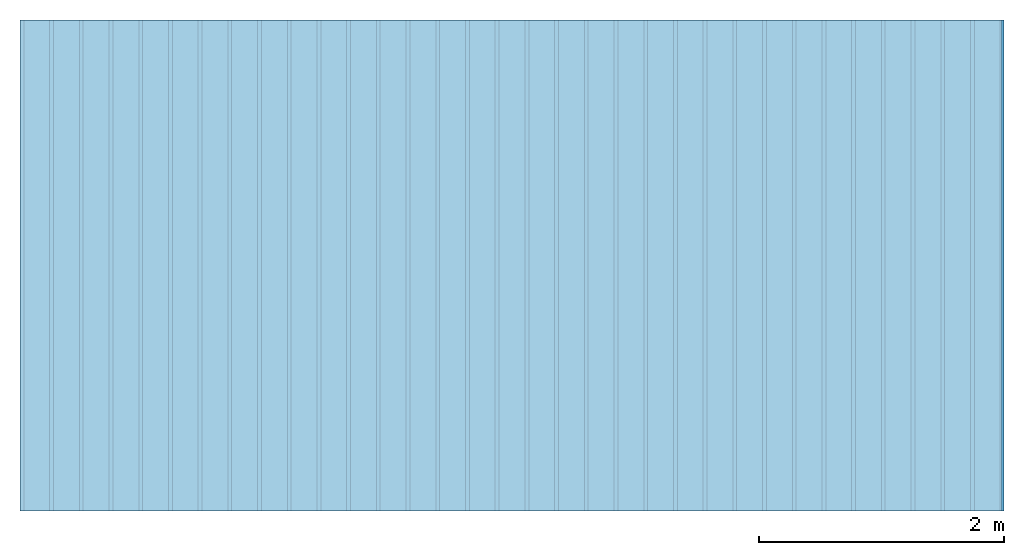
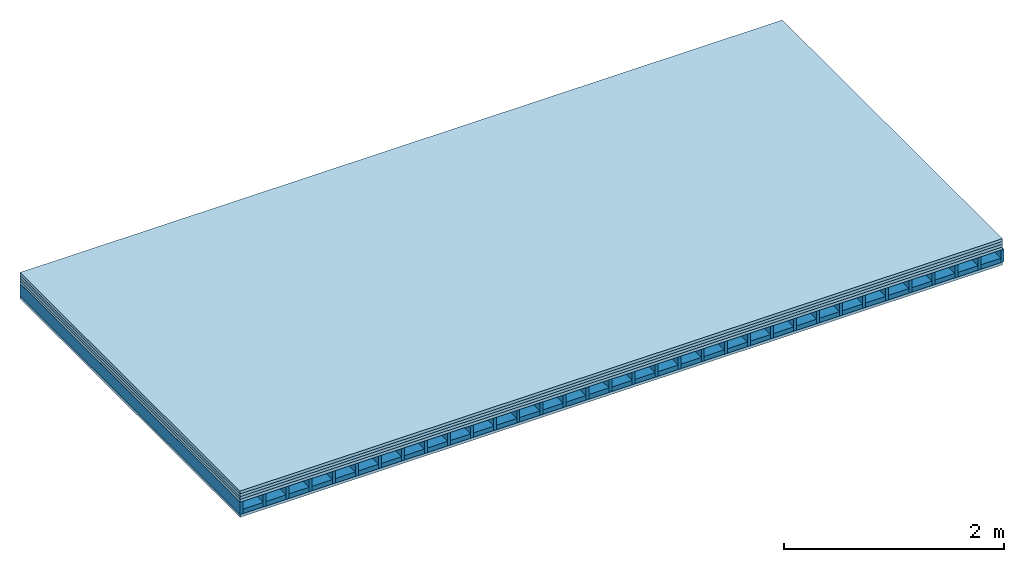
# One storey: 5 plates, 2 members, 1 element without a shape of its own.
"""IFC4 building model written with IfcOpenShell, lengths in metres."""

from ifc_helpers import new_model, si_unit, derived_unit, direction, frame, frame_2d, origin, origin_with_axes, place, context, project, spatial, rectangle, extrude, material, layer, layer_set, type_object, element, aggregate, save


model = new_model("IFC4")

# Units and contexts
plan_context = context("Plan", 3, precision=1e-05, world=origin(), true_north=direction((0.0, 1.0)))
model_context = context("Model", 3, precision=1e-05, world=origin(), true_north=direction((0.0, 1.0)))
ifc_project = project(units=[si_unit("LENGTHUNIT", "METRE"), derived_unit("SOUNDPRESSUREUNIT", [(si_unit("PRESSUREUNIT", "PASCAL", prefix="MICRO"), 0)]), si_unit("ENERGYUNIT", "JOULE", prefix="MEGA"), si_unit("MASSUNIT", "GRAM", prefix="KILO"), derived_unit("THERMALTRANSMITTANCEUNIT", [(si_unit("POWERUNIT", "WATT"), 1), (si_unit("AREAUNIT", "SQUARE_METRE"), -1), (si_unit("THERMODYNAMICTEMPERATUREUNIT", "KELVIN"), -1)]), derived_unit("AREADENSITYUNIT", [(si_unit("MASSUNIT", "GRAM", prefix="KILO"), 1), (si_unit("AREAUNIT", "SQUARE_METRE"), -1)]), derived_unit("USERDEFINED", [(si_unit("ENERGYUNIT", "JOULE", prefix="MEGA"), 1), (si_unit("AREAUNIT", "SQUARE_METRE"), -1)])], contexts=[plan_context, model_context])

# Site, building, storey
site = spatial("IfcSite", under=ifc_project)
building_placement = place(None, origin())
building = spatial("IfcBuilding", under=site, at=building_placement)
storey_placement = place(building_placement, origin())
storey = spatial("IfcBuildingStorey", under=building, at=storey_placement)

# Slab, members, plates
ifc_material_1 = material(Category="03.007")
ifc_layer_1 = layer(ifc_material_1, 0.032, Name="On-material")
ifc_material_2 = material(Name="EP2, 30mm")
ifc_layer_2 = layer(ifc_material_2, 0.03, Name="Impact sound insulation")
ifc_material_3 = material(Category="03.011")
ifc_layer_3 = layer(ifc_material_3, 0.03, Name="on Supporting structure")
ifc_material_4 = material(Name="surface element sheathing above")
ifc_layer_4 = layer(ifc_material_4, 0.031, Name="Sub-floor")
ifc_layer_5 = layer(None, 0.138, Name="Supporting structure")
ifc_material_5 = material(Name="surface element sheathing below")
ifc_layer_6 = layer(ifc_material_5, 0.031, Name="Lower layer 1")
ifc_layer_set = layer_set([ifc_layer_1, ifc_layer_2, ifc_layer_3, ifc_layer_4, ifc_layer_5, ifc_layer_6])
slab_type = type_object("IfcSlabType", Name="A2700", PredefinedType="NOTDEFINED", material=ifc_layer_set)
slab_placement = place(None, frame((0.0, 0.0, 0.0), z_axis=(0.0, 0.0, -1.0), x_axis=(1.0, 0.0, 0.0)))
slab = element("IfcSlab", 1, at=slab_placement, inside=storey, type_object=slab_type, material=ifc_layer_set, Name="Slab #1")
ifc_material_6 = material(Name="surface element LFE")
member_1_placement = place(slab_placement, origin())
member_1 = element("IfcMember", 2, at=member_1_placement, material=ifc_material_6, Name="Supporting structure", context=plan_context, shape_type="SweptSolid", body=[
    extrude(rectangle(XDim=0.031, YDim=0.138, at=frame_2d((0.0155, 0.069), x_axis=(1.0, 0.0))), frame((0.0, 4.0, 0.123), z_axis=(0.0, -1.0, 0.0), x_axis=(1.0, 0.0, 0.0)), (0.0, 0.0, 1.0), 4.0),
    extrude(rectangle(XDim=0.031, YDim=0.138, at=frame_2d((0.0155, 0.069), x_axis=(1.0, 0.0))), frame((0.242, 4.0, 0.123), z_axis=(0.0, -1.0, 0.0), x_axis=(1.0, 0.0, 0.0)), (0.0, 0.0, 1.0), 4.0),
    extrude(rectangle(XDim=0.031, YDim=0.138, at=frame_2d((0.0155, 0.069), x_axis=(1.0, 0.0))), frame((0.484, 4.0, 0.123), z_axis=(0.0, -1.0, 0.0), x_axis=(1.0, 0.0, 0.0)), (0.0, 0.0, 1.0), 4.0),
    extrude(rectangle(XDim=0.031, YDim=0.138, at=frame_2d((0.0155, 0.069), x_axis=(1.0, 0.0))), frame((0.726, 4.0, 0.123), z_axis=(0.0, -1.0, 0.0), x_axis=(1.0, 0.0, 0.0)), (0.0, 0.0, 1.0), 4.0),
    extrude(rectangle(XDim=0.031, YDim=0.138, at=frame_2d((0.0155, 0.069), x_axis=(1.0, 0.0))), frame((0.968, 4.0, 0.123), z_axis=(0.0, -1.0, 0.0), x_axis=(1.0, 0.0, 0.0)), (0.0, 0.0, 1.0), 4.0),
    extrude(rectangle(XDim=0.031, YDim=0.138, at=frame_2d((0.0155, 0.069), x_axis=(1.0, 0.0))), frame((1.21, 4.0, 0.123), z_axis=(0.0, -1.0, 0.0), x_axis=(1.0, 0.0, 0.0)), (0.0, 0.0, 1.0), 4.0),
    extrude(rectangle(XDim=0.031, YDim=0.138, at=frame_2d((0.0155, 0.069), x_axis=(1.0, 0.0))), frame((1.452, 4.0, 0.123), z_axis=(0.0, -1.0, 0.0), x_axis=(1.0, 0.0, 0.0)), (0.0, 0.0, 1.0), 4.0),
    extrude(rectangle(XDim=0.031, YDim=0.138, at=frame_2d((0.0155, 0.069), x_axis=(1.0, 0.0))), frame((1.694, 4.0, 0.123), z_axis=(0.0, -1.0, 0.0), x_axis=(1.0, 0.0, 0.0)), (0.0, 0.0, 1.0), 4.0),
    extrude(rectangle(XDim=0.031, YDim=0.138, at=frame_2d((0.0155, 0.069), x_axis=(1.0, 0.0))), frame((1.936, 4.0, 0.123), z_axis=(0.0, -1.0, 0.0), x_axis=(1.0, 0.0, 0.0)), (0.0, 0.0, 1.0), 4.0),
    extrude(rectangle(XDim=0.031, YDim=0.138, at=frame_2d((0.0155, 0.069), x_axis=(1.0, 0.0))), frame((2.178, 4.0, 0.123), z_axis=(0.0, -1.0, 0.0), x_axis=(1.0, 0.0, 0.0)), (0.0, 0.0, 1.0), 4.0),
    extrude(rectangle(XDim=0.031, YDim=0.138, at=frame_2d((0.0155, 0.069), x_axis=(1.0, 0.0))), frame((2.42, 4.0, 0.123), z_axis=(0.0, -1.0, 0.0), x_axis=(1.0, 0.0, 0.0)), (0.0, 0.0, 1.0), 4.0),
    extrude(rectangle(XDim=0.031, YDim=0.138, at=frame_2d((0.0155, 0.069), x_axis=(1.0, 0.0))), frame((2.662, 4.0, 0.123), z_axis=(0.0, -1.0, 0.0), x_axis=(1.0, 0.0, 0.0)), (0.0, 0.0, 1.0), 4.0),
    extrude(rectangle(XDim=0.031, YDim=0.138, at=frame_2d((0.0155, 0.069), x_axis=(1.0, 0.0))), frame((2.904, 4.0, 0.123), z_axis=(0.0, -1.0, 0.0), x_axis=(1.0, 0.0, 0.0)), (0.0, 0.0, 1.0), 4.0),
    extrude(rectangle(XDim=0.031, YDim=0.138, at=frame_2d((0.0155, 0.069), x_axis=(1.0, 0.0))), frame((3.146, 4.0, 0.123), z_axis=(0.0, -1.0, 0.0), x_axis=(1.0, 0.0, 0.0)), (0.0, 0.0, 1.0), 4.0),
    extrude(rectangle(XDim=0.031, YDim=0.138, at=frame_2d((0.0155, 0.069), x_axis=(1.0, 0.0))), frame((3.388, 4.0, 0.123), z_axis=(0.0, -1.0, 0.0), x_axis=(1.0, 0.0, 0.0)), (0.0, 0.0, 1.0), 4.0),
    extrude(rectangle(XDim=0.031, YDim=0.138, at=frame_2d((0.0155, 0.069), x_axis=(1.0, 0.0))), frame((3.63, 4.0, 0.123), z_axis=(0.0, -1.0, 0.0), x_axis=(1.0, 0.0, 0.0)), (0.0, 0.0, 1.0), 4.0),
    extrude(rectangle(XDim=0.031, YDim=0.138, at=frame_2d((0.0155, 0.069), x_axis=(1.0, 0.0))), frame((3.872, 4.0, 0.123), z_axis=(0.0, -1.0, 0.0), x_axis=(1.0, 0.0, 0.0)), (0.0, 0.0, 1.0), 4.0),
    extrude(rectangle(XDim=0.031, YDim=0.138, at=frame_2d((0.0155, 0.069), x_axis=(1.0, 0.0))), frame((4.114, 4.0, 0.123), z_axis=(0.0, -1.0, 0.0), x_axis=(1.0, 0.0, 0.0)), (0.0, 0.0, 1.0), 4.0),
    extrude(rectangle(XDim=0.031, YDim=0.138, at=frame_2d((0.0155, 0.069), x_axis=(1.0, 0.0))), frame((4.356, 4.0, 0.123), z_axis=(0.0, -1.0, 0.0), x_axis=(1.0, 0.0, 0.0)), (0.0, 0.0, 1.0), 4.0),
    extrude(rectangle(XDim=0.031, YDim=0.138, at=frame_2d((0.0155, 0.069), x_axis=(1.0, 0.0))), frame((4.598, 4.0, 0.123), z_axis=(0.0, -1.0, 0.0), x_axis=(1.0, 0.0, 0.0)), (0.0, 0.0, 1.0), 4.0),
    extrude(rectangle(XDim=0.031, YDim=0.138, at=frame_2d((0.0155, 0.069), x_axis=(1.0, 0.0))), frame((4.84, 4.0, 0.123), z_axis=(0.0, -1.0, 0.0), x_axis=(1.0, 0.0, 0.0)), (0.0, 0.0, 1.0), 4.0),
    extrude(rectangle(XDim=0.031, YDim=0.138, at=frame_2d((0.0155, 0.069), x_axis=(1.0, 0.0))), frame((5.082, 4.0, 0.123), z_axis=(0.0, -1.0, 0.0), x_axis=(1.0, 0.0, 0.0)), (0.0, 0.0, 1.0), 4.0),
    extrude(rectangle(XDim=0.031, YDim=0.138, at=frame_2d((0.0155, 0.069), x_axis=(1.0, 0.0))), frame((5.324, 4.0, 0.123), z_axis=(0.0, -1.0, 0.0), x_axis=(1.0, 0.0, 0.0)), (0.0, 0.0, 1.0), 4.0),
    extrude(rectangle(XDim=0.031, YDim=0.138, at=frame_2d((0.0155, 0.069), x_axis=(1.0, 0.0))), frame((5.566, 4.0, 0.123), z_axis=(0.0, -1.0, 0.0), x_axis=(1.0, 0.0, 0.0)), (0.0, 0.0, 1.0), 4.0),
    extrude(rectangle(XDim=0.031, YDim=0.138, at=frame_2d((0.0155, 0.069), x_axis=(1.0, 0.0))), frame((5.808, 4.0, 0.123), z_axis=(0.0, -1.0, 0.0), x_axis=(1.0, 0.0, 0.0)), (0.0, 0.0, 1.0), 4.0),
    extrude(rectangle(XDim=0.031, YDim=0.138, at=frame_2d((0.0155, 0.069), x_axis=(1.0, 0.0))), frame((6.05, 4.0, 0.123), z_axis=(0.0, -1.0, 0.0), x_axis=(1.0, 0.0, 0.0)), (0.0, 0.0, 1.0), 4.0),
    extrude(rectangle(XDim=0.031, YDim=0.138, at=frame_2d((0.0155, 0.069), x_axis=(1.0, 0.0))), frame((6.292, 4.0, 0.123), z_axis=(0.0, -1.0, 0.0), x_axis=(1.0, 0.0, 0.0)), (0.0, 0.0, 1.0), 4.0),
    extrude(rectangle(XDim=0.031, YDim=0.138, at=frame_2d((0.0155, 0.069), x_axis=(1.0, 0.0))), frame((6.534, 4.0, 0.123), z_axis=(0.0, -1.0, 0.0), x_axis=(1.0, 0.0, 0.0)), (0.0, 0.0, 1.0), 4.0),
    extrude(rectangle(XDim=0.031, YDim=0.138, at=frame_2d((0.0155, 0.069), x_axis=(1.0, 0.0))), frame((6.776, 4.0, 0.123), z_axis=(0.0, -1.0, 0.0), x_axis=(1.0, 0.0, 0.0)), (0.0, 0.0, 1.0), 4.0),
    extrude(rectangle(XDim=0.031, YDim=0.138, at=frame_2d((0.0155, 0.069), x_axis=(1.0, 0.0))), frame((7.018, 4.0, 0.123), z_axis=(0.0, -1.0, 0.0), x_axis=(1.0, 0.0, 0.0)), (0.0, 0.0, 1.0), 4.0),
    extrude(rectangle(XDim=0.031, YDim=0.138, at=frame_2d((0.0155, 0.069), x_axis=(1.0, 0.0))), frame((7.26, 4.0, 0.123), z_axis=(0.0, -1.0, 0.0), x_axis=(1.0, 0.0, 0.0)), (0.0, 0.0, 1.0), 4.0),
    extrude(rectangle(XDim=0.031, YDim=0.138, at=frame_2d((0.0155, 0.069), x_axis=(1.0, 0.0))), frame((7.502, 4.0, 0.123), z_axis=(0.0, -1.0, 0.0), x_axis=(1.0, 0.0, 0.0)), (0.0, 0.0, 1.0), 4.0),
    extrude(rectangle(XDim=0.031, YDim=0.138, at=frame_2d((0.0155, 0.069), x_axis=(1.0, 0.0))), frame((7.744, 4.0, 0.123), z_axis=(0.0, -1.0, 0.0), x_axis=(1.0, 0.0, 0.0)), (0.0, 0.0, 1.0), 4.0),
    extrude(rectangle(XDim=0.031, YDim=0.138, at=frame_2d((0.0155, 0.069), x_axis=(1.0, 0.0))), frame((7.986, 4.0, 0.123), z_axis=(0.0, -1.0, 0.0), x_axis=(1.0, 0.0, 0.0)), (0.0, 0.0, 1.0), 4.0),
])
member_2_placement = place(slab_placement, origin())
member_2 = element("IfcMember", 3, at=member_2_placement, material=ifc_material_3, Name="in supporting structure", context=plan_context, shape_type="SweptSolid", body=[
    extrude(rectangle(XDim=0.211, YDim=0.049, at=frame_2d((0.1055, 0.0245), x_axis=(1.0, 0.0))), frame((0.031, 4.0, 0.212), z_axis=(0.0, -1.0, 0.0), x_axis=(1.0, 0.0, 0.0)), (0.0, 0.0, 1.0), 4.0),
    extrude(rectangle(XDim=0.211, YDim=0.049, at=frame_2d((0.1055, 0.0245), x_axis=(1.0, 0.0))), frame((0.273, 4.0, 0.212), z_axis=(0.0, -1.0, 0.0), x_axis=(1.0, 0.0, 0.0)), (0.0, 0.0, 1.0), 4.0),
    extrude(rectangle(XDim=0.211, YDim=0.049, at=frame_2d((0.1055, 0.0245), x_axis=(1.0, 0.0))), frame((0.515, 4.0, 0.212), z_axis=(0.0, -1.0, 0.0), x_axis=(1.0, 0.0, 0.0)), (0.0, 0.0, 1.0), 4.0),
    extrude(rectangle(XDim=0.211, YDim=0.049, at=frame_2d((0.1055, 0.0245), x_axis=(1.0, 0.0))), frame((0.757, 4.0, 0.212), z_axis=(0.0, -1.0, 0.0), x_axis=(1.0, 0.0, 0.0)), (0.0, 0.0, 1.0), 4.0),
    extrude(rectangle(XDim=0.211, YDim=0.049, at=frame_2d((0.1055, 0.0245), x_axis=(1.0, 0.0))), frame((0.999, 4.0, 0.212), z_axis=(0.0, -1.0, 0.0), x_axis=(1.0, 0.0, 0.0)), (0.0, 0.0, 1.0), 4.0),
    extrude(rectangle(XDim=0.211, YDim=0.049, at=frame_2d((0.1055, 0.0245), x_axis=(1.0, 0.0))), frame((1.241, 4.0, 0.212), z_axis=(0.0, -1.0, 0.0), x_axis=(1.0, 0.0, 0.0)), (0.0, 0.0, 1.0), 4.0),
    extrude(rectangle(XDim=0.211, YDim=0.049, at=frame_2d((0.1055, 0.0245), x_axis=(1.0, 0.0))), frame((1.483, 4.0, 0.212), z_axis=(0.0, -1.0, 0.0), x_axis=(1.0, 0.0, 0.0)), (0.0, 0.0, 1.0), 4.0),
    extrude(rectangle(XDim=0.211, YDim=0.049, at=frame_2d((0.1055, 0.0245), x_axis=(1.0, 0.0))), frame((1.725, 4.0, 0.212), z_axis=(0.0, -1.0, 0.0), x_axis=(1.0, 0.0, 0.0)), (0.0, 0.0, 1.0), 4.0),
    extrude(rectangle(XDim=0.211, YDim=0.049, at=frame_2d((0.1055, 0.0245), x_axis=(1.0, 0.0))), frame((1.967, 4.0, 0.212), z_axis=(0.0, -1.0, 0.0), x_axis=(1.0, 0.0, 0.0)), (0.0, 0.0, 1.0), 4.0),
    extrude(rectangle(XDim=0.211, YDim=0.049, at=frame_2d((0.1055, 0.0245), x_axis=(1.0, 0.0))), frame((2.209, 4.0, 0.212), z_axis=(0.0, -1.0, 0.0), x_axis=(1.0, 0.0, 0.0)), (0.0, 0.0, 1.0), 4.0),
    extrude(rectangle(XDim=0.211, YDim=0.049, at=frame_2d((0.1055, 0.0245), x_axis=(1.0, 0.0))), frame((2.451, 4.0, 0.212), z_axis=(0.0, -1.0, 0.0), x_axis=(1.0, 0.0, 0.0)), (0.0, 0.0, 1.0), 4.0),
    extrude(rectangle(XDim=0.211, YDim=0.049, at=frame_2d((0.1055, 0.0245), x_axis=(1.0, 0.0))), frame((2.693, 4.0, 0.212), z_axis=(0.0, -1.0, 0.0), x_axis=(1.0, 0.0, 0.0)), (0.0, 0.0, 1.0), 4.0),
    extrude(rectangle(XDim=0.211, YDim=0.049, at=frame_2d((0.1055, 0.0245), x_axis=(1.0, 0.0))), frame((2.935, 4.0, 0.212), z_axis=(0.0, -1.0, 0.0), x_axis=(1.0, 0.0, 0.0)), (0.0, 0.0, 1.0), 4.0),
    extrude(rectangle(XDim=0.211, YDim=0.049, at=frame_2d((0.1055, 0.0245), x_axis=(1.0, 0.0))), frame((3.177, 4.0, 0.212), z_axis=(0.0, -1.0, 0.0), x_axis=(1.0, 0.0, 0.0)), (0.0, 0.0, 1.0), 4.0),
    extrude(rectangle(XDim=0.211, YDim=0.049, at=frame_2d((0.1055, 0.0245), x_axis=(1.0, 0.0))), frame((3.419, 4.0, 0.212), z_axis=(0.0, -1.0, 0.0), x_axis=(1.0, 0.0, 0.0)), (0.0, 0.0, 1.0), 4.0),
    extrude(rectangle(XDim=0.211, YDim=0.049, at=frame_2d((0.1055, 0.0245), x_axis=(1.0, 0.0))), frame((3.661, 4.0, 0.212), z_axis=(0.0, -1.0, 0.0), x_axis=(1.0, 0.0, 0.0)), (0.0, 0.0, 1.0), 4.0),
    extrude(rectangle(XDim=0.211, YDim=0.049, at=frame_2d((0.1055, 0.0245), x_axis=(1.0, 0.0))), frame((3.903, 4.0, 0.212), z_axis=(0.0, -1.0, 0.0), x_axis=(1.0, 0.0, 0.0)), (0.0, 0.0, 1.0), 4.0),
    extrude(rectangle(XDim=0.211, YDim=0.049, at=frame_2d((0.1055, 0.0245), x_axis=(1.0, 0.0))), frame((4.145, 4.0, 0.212), z_axis=(0.0, -1.0, 0.0), x_axis=(1.0, 0.0, 0.0)), (0.0, 0.0, 1.0), 4.0),
    extrude(rectangle(XDim=0.211, YDim=0.049, at=frame_2d((0.1055, 0.0245), x_axis=(1.0, 0.0))), frame((4.387, 4.0, 0.212), z_axis=(0.0, -1.0, 0.0), x_axis=(1.0, 0.0, 0.0)), (0.0, 0.0, 1.0), 4.0),
    extrude(rectangle(XDim=0.211, YDim=0.049, at=frame_2d((0.1055, 0.0245), x_axis=(1.0, 0.0))), frame((4.629, 4.0, 0.212), z_axis=(0.0, -1.0, 0.0), x_axis=(1.0, 0.0, 0.0)), (0.0, 0.0, 1.0), 4.0),
    extrude(rectangle(XDim=0.211, YDim=0.049, at=frame_2d((0.1055, 0.0245), x_axis=(1.0, 0.0))), frame((4.871, 4.0, 0.212), z_axis=(0.0, -1.0, 0.0), x_axis=(1.0, 0.0, 0.0)), (0.0, 0.0, 1.0), 4.0),
    extrude(rectangle(XDim=0.211, YDim=0.049, at=frame_2d((0.1055, 0.0245), x_axis=(1.0, 0.0))), frame((5.113, 4.0, 0.212), z_axis=(0.0, -1.0, 0.0), x_axis=(1.0, 0.0, 0.0)), (0.0, 0.0, 1.0), 4.0),
    extrude(rectangle(XDim=0.211, YDim=0.049, at=frame_2d((0.1055, 0.0245), x_axis=(1.0, 0.0))), frame((5.355, 4.0, 0.212), z_axis=(0.0, -1.0, 0.0), x_axis=(1.0, 0.0, 0.0)), (0.0, 0.0, 1.0), 4.0),
    extrude(rectangle(XDim=0.211, YDim=0.049, at=frame_2d((0.1055, 0.0245), x_axis=(1.0, 0.0))), frame((5.597, 4.0, 0.212), z_axis=(0.0, -1.0, 0.0), x_axis=(1.0, 0.0, 0.0)), (0.0, 0.0, 1.0), 4.0),
    extrude(rectangle(XDim=0.211, YDim=0.049, at=frame_2d((0.1055, 0.0245), x_axis=(1.0, 0.0))), frame((5.839, 4.0, 0.212), z_axis=(0.0, -1.0, 0.0), x_axis=(1.0, 0.0, 0.0)), (0.0, 0.0, 1.0), 4.0),
    extrude(rectangle(XDim=0.211, YDim=0.049, at=frame_2d((0.1055, 0.0245), x_axis=(1.0, 0.0))), frame((6.081, 4.0, 0.212), z_axis=(0.0, -1.0, 0.0), x_axis=(1.0, 0.0, 0.0)), (0.0, 0.0, 1.0), 4.0),
    extrude(rectangle(XDim=0.211, YDim=0.049, at=frame_2d((0.1055, 0.0245), x_axis=(1.0, 0.0))), frame((6.323, 4.0, 0.212), z_axis=(0.0, -1.0, 0.0), x_axis=(1.0, 0.0, 0.0)), (0.0, 0.0, 1.0), 4.0),
    extrude(rectangle(XDim=0.211, YDim=0.049, at=frame_2d((0.1055, 0.0245), x_axis=(1.0, 0.0))), frame((6.565, 4.0, 0.212), z_axis=(0.0, -1.0, 0.0), x_axis=(1.0, 0.0, 0.0)), (0.0, 0.0, 1.0), 4.0),
    extrude(rectangle(XDim=0.211, YDim=0.049, at=frame_2d((0.1055, 0.0245), x_axis=(1.0, 0.0))), frame((6.807, 4.0, 0.212), z_axis=(0.0, -1.0, 0.0), x_axis=(1.0, 0.0, 0.0)), (0.0, 0.0, 1.0), 4.0),
    extrude(rectangle(XDim=0.211, YDim=0.049, at=frame_2d((0.1055, 0.0245), x_axis=(1.0, 0.0))), frame((7.049, 4.0, 0.212), z_axis=(0.0, -1.0, 0.0), x_axis=(1.0, 0.0, 0.0)), (0.0, 0.0, 1.0), 4.0),
    extrude(rectangle(XDim=0.211, YDim=0.049, at=frame_2d((0.1055, 0.0245), x_axis=(1.0, 0.0))), frame((7.291, 4.0, 0.212), z_axis=(0.0, -1.0, 0.0), x_axis=(1.0, 0.0, 0.0)), (0.0, 0.0, 1.0), 4.0),
    extrude(rectangle(XDim=0.211, YDim=0.049, at=frame_2d((0.1055, 0.0245), x_axis=(1.0, 0.0))), frame((7.533, 4.0, 0.212), z_axis=(0.0, -1.0, 0.0), x_axis=(1.0, 0.0, 0.0)), (0.0, 0.0, 1.0), 4.0),
    extrude(rectangle(XDim=0.211, YDim=0.049, at=frame_2d((0.1055, 0.0245), x_axis=(1.0, 0.0))), frame((7.775, 4.0, 0.212), z_axis=(0.0, -1.0, 0.0), x_axis=(1.0, 0.0, 0.0)), (0.0, 0.0, 1.0), 4.0),
])
plate_1_placement = place(slab_placement, origin())
plate_1 = element("IfcPlate", 4, at=plate_1_placement, material=ifc_material_1, Name="On-material", context=plan_context, shape_type="SweptSolid", body=[
    extrude(rectangle(XDim=8.0, YDim=4.0, at=frame_2d((4.0, 2.0), x_axis=(1.0, 0.0))), origin_with_axes(), (0.0, 0.0, 1.0), 0.032),
])
plate_2_placement = place(slab_placement, origin())
plate_2 = element("IfcPlate", 5, at=plate_2_placement, material=ifc_material_2, Name="Impact sound insulation", context=plan_context, shape_type="SweptSolid", body=[
    extrude(rectangle(XDim=8.0, YDim=4.0, at=frame_2d((4.0, 2.0), x_axis=(1.0, 0.0))), frame((0.0, 0.0, 0.032), z_axis=(0.0, 0.0, 1.0), x_axis=(1.0, 0.0, 0.0)), (0.0, 0.0, 1.0), 0.03),
])
plate_3_placement = place(slab_placement, origin())
plate_3 = element("IfcPlate", 6, at=plate_3_placement, material=ifc_material_3, Name="on Supporting structure", context=plan_context, shape_type="SweptSolid", body=[
    extrude(rectangle(XDim=8.0, YDim=4.0, at=frame_2d((4.0, 2.0), x_axis=(1.0, 0.0))), frame((0.0, 0.0, 0.062), z_axis=(0.0, 0.0, 1.0), x_axis=(1.0, 0.0, 0.0)), (0.0, 0.0, 1.0), 0.03),
])
plate_4_placement = place(slab_placement, origin())
plate_4 = element("IfcPlate", 7, at=plate_4_placement, material=ifc_material_4, Name="Sub-floor", context=plan_context, shape_type="SweptSolid", body=[
    extrude(rectangle(XDim=8.0, YDim=4.0, at=frame_2d((4.0, 2.0), x_axis=(1.0, 0.0))), frame((0.0, 0.0, 0.092), z_axis=(0.0, 0.0, 1.0), x_axis=(1.0, 0.0, 0.0)), (0.0, 0.0, 1.0), 0.031),
])
plate_5_placement = place(slab_placement, origin())
plate_5 = element("IfcPlate", 8, at=plate_5_placement, material=ifc_material_5, Name="Lower layer 1", context=plan_context, shape_type="SweptSolid", body=[
    extrude(rectangle(XDim=8.0, YDim=4.0, at=frame_2d((4.0, 2.0), x_axis=(1.0, 0.0))), frame((0.0, 0.0, 0.261), z_axis=(0.0, 0.0, 1.0), x_axis=(1.0, 0.0, 0.0)), (0.0, 0.0, 1.0), 0.031),
])
aggregate(slab, [plate_1, plate_2, plate_3, plate_4, member_1, member_2, plate_5])

save(model, "model.ifc")
